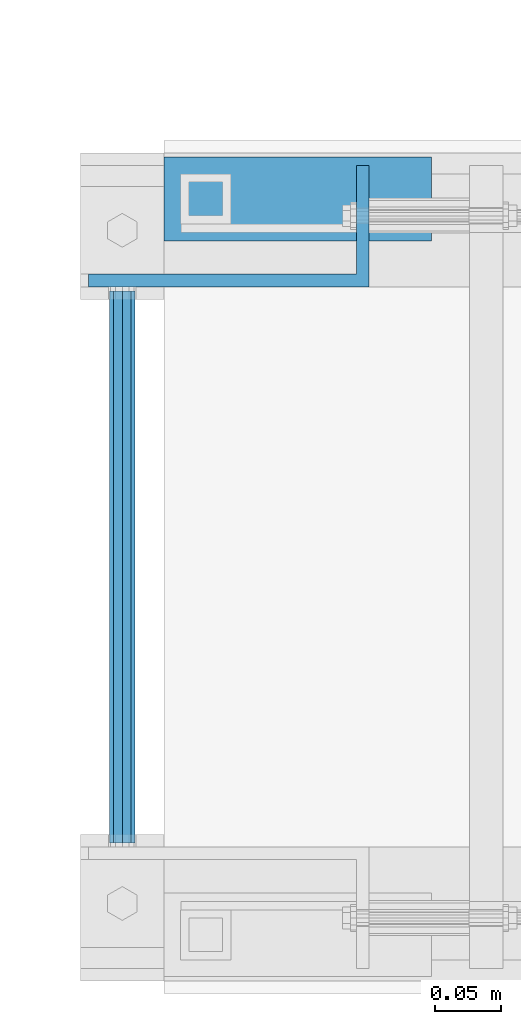
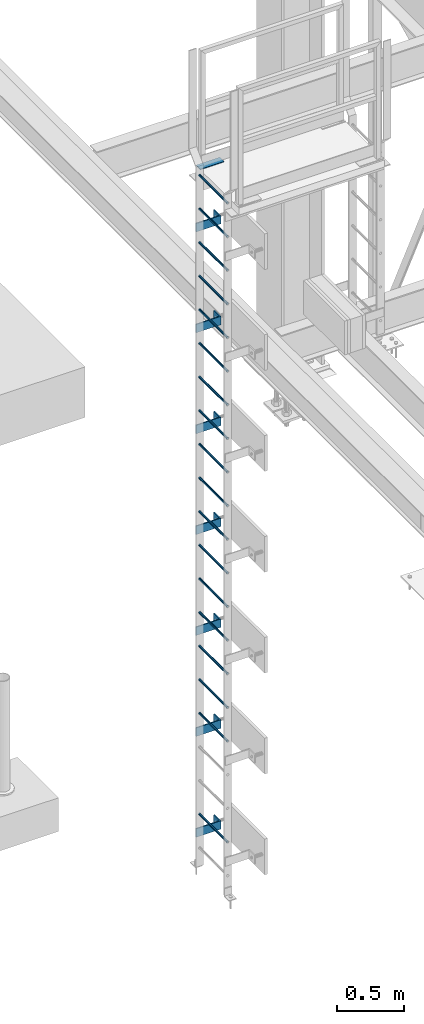
# One storey, part 2015 of 3843: 26 beams, 2 elements without a shape of their own.
"""IFC2X3 building model written with IfcOpenShell, lengths in millimetres."""

from ifc_helpers import new_model, si_unit, frame, origin_with_axes, place, context, subcontext, project, spatial, faceted_brep, material, type_object, element, aggregate, save


model = new_model("IFC2X3")

# Units and contexts
model_context = context("Model", 3, precision=1e-05, world=origin_with_axes())
body_context = subcontext(model_context, "Body", "Model", "MODEL_VIEW")
ifc_project = project(units=[si_unit("LENGTHUNIT", "METRE", prefix="MILLI"), si_unit("AREAUNIT", "SQUARE_METRE"), si_unit("VOLUMEUNIT", "CUBIC_METRE"), si_unit("MASSUNIT", "GRAM", prefix="KILO"), si_unit("TIMEUNIT", "SECOND"), si_unit("PLANEANGLEUNIT", "RADIAN"), si_unit("SOLIDANGLEUNIT", "STERADIAN"), si_unit("THERMODYNAMICTEMPERATUREUNIT", "DEGREE_CELSIUS"), si_unit("LUMINOUSINTENSITYUNIT", "LUMEN")], contexts=[model_context])

# Site, building, storey
site_placement = place(None, origin_with_axes())
site = spatial("IfcSite", under=ifc_project, at=site_placement, CompositionType="ELEMENT")
building_placement = place(site_placement, origin_with_axes())
building = spatial("IfcBuilding", under=site, at=building_placement, Name="Undefined", CompositionType="ELEMENT")
storey_placement = place(building_placement, origin_with_axes())
storey = spatial("IfcBuildingStorey", under=building, at=storey_placement, Name="Undefined", CompositionType="ELEMENT", Elevation=0.0)

# Assembly, beams
assembly_1_placement = place(storey_placement, origin_with_axes())
assembly_1 = element("IfcElementAssembly", 1, at=assembly_1_placement, inside=storey, Name="LADDER", AssemblyPlace="NOTDEFINED", PredefinedType="RIGID_FRAME")
ifc_material_1 = material(Name="STEEL/A36")
beam_type_1 = type_object("IfcBeamType", PredefinedType="NOTDEFINED")
beam_1_placement = place(assembly_1_placement, frame((32400.1940668828, 28017.7875000009, 36281.9334228516), z_axis=(0.0, 0.0, 1.0), x_axis=(1.0, 0.0, 0.0)))
beam_1 = element("IfcBeam", 2, at=beam_1_placement, type_object=beam_type_1, material=ifc_material_1, Name="BENT_PLATE", context=body_context, shape_type="Brep", body=[
    faceted_brep([(0.0, -4.76250000000073, -38.0999999999985), (0.0, -4.76250000000073, 38.0999999999985), (0.0, 4.76250000000073, 38.0999999999985), (0.0, 4.76250000000073, -38.0999999999985), (203.398438000007, 4.762500000008, 38.0999999999985), (203.398438000007, 4.762500000008, -38.0999999999985), (212.923438000009, -4.76249999999345, -38.0999999999985), (212.923438000009, -4.76249999999345, 38.0999999999985), (203.398438000007, 87.312499999498, 38.0999999999985), (203.398438000007, 87.312499999498, -38.0999999999985), (212.923438000009, 87.312499999498, 38.0999999999985), (212.923438000009, 87.312499999498, -38.0999999999985)], [[[0, 1, 2, 3]], [[3, 2, 4, 5]], [[1, 0, 6, 7]], [[5, 4, 8, 9]], [[4, 2, 1, 7, 10, 8]], [[7, 6, 11, 10]], [[6, 0, 3, 5, 9, 11]], [[10, 11, 9, 8]]]),
])
beam_2_placement = place(assembly_1_placement, frame((32400.1940668828, 28017.7875000009, 35367.5334228516), z_axis=(0.0, 0.0, 1.0), x_axis=(1.0, 0.0, 0.0)))
beam_2 = element("IfcBeam", 3, at=beam_2_placement, type_object=beam_type_1, material=ifc_material_1, Name="BENT_PLATE", context=body_context, shape_type="Brep", body=[
    faceted_brep([(0.0, -4.76250000000073, -38.0999999999985), (0.0, -4.76250000000073, 38.0999999999985), (0.0, 4.76250000000073, 38.0999999999985), (0.0, 4.76250000000073, -38.0999999999985), (203.398438000007, 4.762500000008, 38.0999999999985), (203.398438000007, 4.762500000008, -38.0999999999985), (212.923438000009, -4.76249999999345, -38.0999999999985), (212.923438000009, -4.76249999999345, 38.0999999999985), (203.398438000007, 87.312499999498, 38.0999999999985), (203.398438000007, 87.312499999498, -38.0999999999985), (212.923438000009, 87.312499999498, 38.0999999999985), (212.923438000009, 87.312499999498, -38.0999999999985)], [[[0, 1, 2, 3]], [[3, 2, 4, 5]], [[1, 0, 6, 7]], [[5, 4, 8, 9]], [[4, 2, 1, 7, 10, 8]], [[7, 6, 11, 10]], [[6, 0, 3, 5, 9, 11]], [[10, 11, 9, 8]]]),
])
beam_3_placement = place(assembly_1_placement, frame((32400.1940668828, 28017.7875000009, 34453.1334228516), z_axis=(0.0, 0.0, 1.0), x_axis=(1.0, 0.0, 0.0)))
beam_3 = element("IfcBeam", 4, at=beam_3_placement, type_object=beam_type_1, material=ifc_material_1, Name="BENT_PLATE", context=body_context, shape_type="Brep", body=[
    faceted_brep([(0.0, -4.76250000000073, -38.0999999999985), (0.0, -4.76250000000073, 38.0999999999985), (0.0, 4.76250000000073, 38.0999999999985), (0.0, 4.76250000000073, -38.0999999999985), (203.398438000007, 4.762500000008, 38.0999999999985), (203.398438000007, 4.762500000008, -38.0999999999985), (212.923438000009, -4.76249999999345, -38.0999999999985), (212.923438000009, -4.76249999999345, 38.0999999999985), (203.398438000007, 87.312499999498, 38.0999999999985), (203.398438000007, 87.312499999498, -38.0999999999985), (212.923438000009, 87.312499999498, 38.0999999999985), (212.923438000009, 87.312499999498, -38.0999999999985)], [[[0, 1, 2, 3]], [[3, 2, 4, 5]], [[1, 0, 6, 7]], [[5, 4, 8, 9]], [[4, 2, 1, 7, 10, 8]], [[7, 6, 11, 10]], [[6, 0, 3, 5, 9, 11]], [[10, 11, 9, 8]]]),
])
beam_4_placement = place(assembly_1_placement, frame((32400.1940668828, 28017.7875000009, 33538.7334228516), z_axis=(0.0, 0.0, 1.0), x_axis=(1.0, 0.0, 0.0)))
beam_4 = element("IfcBeam", 5, at=beam_4_placement, type_object=beam_type_1, material=ifc_material_1, Name="BENT_PLATE", context=body_context, shape_type="Brep", body=[
    faceted_brep([(0.0, -4.76250000000073, -38.0999999999985), (0.0, -4.76250000000073, 38.0999999999985), (0.0, 4.76250000000073, 38.0999999999985), (0.0, 4.76250000000073, -38.0999999999985), (203.398438000007, 4.762500000008, 38.0999999999985), (203.398438000007, 4.762500000008, -38.0999999999985), (212.923438000009, -4.76249999999345, -38.0999999999985), (212.923438000009, -4.76249999999345, 38.0999999999985), (203.398438000007, 87.312499999498, 38.0999999999985), (203.398438000007, 87.312499999498, -38.0999999999985), (212.923438000009, 87.312499999498, 38.0999999999985), (212.923438000009, 87.312499999498, -38.0999999999985)], [[[0, 1, 2, 3]], [[3, 2, 4, 5]], [[1, 0, 6, 7]], [[5, 4, 8, 9]], [[4, 2, 1, 7, 10, 8]], [[7, 6, 11, 10]], [[6, 0, 3, 5, 9, 11]], [[10, 11, 9, 8]]]),
])
beam_5_placement = place(assembly_1_placement, frame((32400.1940668828, 28017.7875000009, 32624.3334228516), z_axis=(0.0, 0.0, 1.0), x_axis=(1.0, 0.0, 0.0)))
beam_5 = element("IfcBeam", 6, at=beam_5_placement, type_object=beam_type_1, material=ifc_material_1, Name="BENT_PLATE", context=body_context, shape_type="Brep", body=[
    faceted_brep([(0.0, -4.76250000000073, -38.0999999999985), (0.0, -4.76250000000073, 38.0999999999985), (0.0, 4.76250000000073, 38.0999999999985), (0.0, 4.76250000000073, -38.0999999999985), (203.398438000007, 4.762500000008, 38.0999999999985), (203.398438000007, 4.762500000008, -38.0999999999985), (212.923438000009, -4.76249999999345, -38.0999999999985), (212.923438000009, -4.76249999999345, 38.0999999999985), (203.398438000007, 87.312499999498, 38.0999999999985), (203.398438000007, 87.312499999498, -38.0999999999985), (212.923438000009, 87.312499999498, 38.0999999999985), (212.923438000009, 87.312499999498, -38.0999999999985)], [[[0, 1, 2, 3]], [[3, 2, 4, 5]], [[1, 0, 6, 7]], [[5, 4, 8, 9]], [[4, 2, 1, 7, 10, 8]], [[7, 6, 11, 10]], [[6, 0, 3, 5, 9, 11]], [[10, 11, 9, 8]]]),
])
beam_6_placement = place(assembly_1_placement, frame((32400.1940668828, 28017.7875000009, 31709.9334228516), z_axis=(0.0, 0.0, 1.0), x_axis=(1.0, 0.0, 0.0)))
beam_6 = element("IfcBeam", 7, at=beam_6_placement, type_object=beam_type_1, material=ifc_material_1, Name="BENT_PLATE", context=body_context, shape_type="Brep", body=[
    faceted_brep([(0.0, -4.76250000000073, -38.0999999999985), (0.0, -4.76250000000073, 38.0999999999985), (0.0, 4.76250000000073, 38.0999999999985), (0.0, 4.76250000000073, -38.0999999999985), (203.398438000007, 4.762500000008, 38.0999999999985), (203.398438000007, 4.762500000008, -38.0999999999985), (212.923438000009, -4.76249999999345, -38.0999999999985), (212.923438000009, -4.76249999999345, 38.0999999999985), (203.398438000007, 87.312499999498, 38.0999999999985), (203.398438000007, 87.312499999498, -38.0999999999985), (212.923438000009, 87.312499999498, 38.0999999999985), (212.923438000009, 87.312499999498, -38.0999999999985)], [[[0, 1, 2, 3]], [[3, 2, 4, 5]], [[1, 0, 6, 7]], [[5, 4, 8, 9]], [[4, 2, 1, 7, 10, 8]], [[7, 6, 11, 10]], [[6, 0, 3, 5, 9, 11]], [[10, 11, 9, 8]]]),
])
beam_7_placement = place(assembly_1_placement, frame((32400.1940668828, 28017.7875000009, 30795.5334228516), z_axis=(0.0, 0.0, 1.0), x_axis=(1.0, 0.0, 0.0)))
beam_7 = element("IfcBeam", 8, at=beam_7_placement, type_object=beam_type_1, material=ifc_material_1, Name="BENT_PLATE", context=body_context, shape_type="Brep", body=[
    faceted_brep([(0.0, -4.76250000000073, -38.0999999999985), (0.0, -4.76250000000073, 38.0999999999985), (0.0, 4.76250000000073, 38.0999999999985), (0.0, 4.76250000000073, -38.0999999999985), (203.398438000007, 4.762500000008, 38.0999999999985), (203.398438000007, 4.762500000008, -38.0999999999985), (212.923438000009, -4.76249999999345, -38.0999999999985), (212.923438000009, -4.76249999999345, 38.0999999999985), (203.398438000007, 87.312499999498, 38.0999999999985), (203.398438000007, 87.312499999498, -38.0999999999985), (212.923438000009, 87.312499999498, 38.0999999999985), (212.923438000009, 87.312499999498, -38.0999999999985)], [[[0, 1, 2, 3]], [[3, 2, 4, 5]], [[1, 0, 6, 7]], [[5, 4, 8, 9]], [[4, 2, 1, 7, 10, 8]], [[7, 6, 11, 10]], [[6, 0, 3, 5, 9, 11]], [[10, 11, 9, 8]]]),
])
ifc_material_2 = material(Name="STEEL/A572-50")
beam_type_2 = type_object("IfcBeamType", PredefinedType="NOTDEFINED")
beam_8_placement = place(assembly_1_placement, frame((32425.7733459473, 28009.8499999999, 31878.7155151367), z_axis=(1.0, 0.0, 0.0), x_axis=(0.0, -1.0, 0.0)))
beam_8 = element("IfcBeam", 9, at=beam_8_placement, type_object=beam_type_2, material=ifc_material_2, Name="RUNG", context=body_context, shape_type="Brep", body=[
    faceted_brep([(0.0, -9.52500000000146, 0.0), (0.0, -6.73519209080405, -6.73519209079677), (419.100000000006, -6.73519209080405, -6.73519209079677), (419.100000000006, -9.52500000000146, 0.0), (2.95075507493764e-12, 2.91322521661641e-12, -9.52499961853027), (419.100000000006, 0.0, -9.52499999999418), (0.0, 6.73519209080405, -6.73519209079677), (419.100000000006, 6.73519209080405, -6.73519209079677), (0.0, 9.52500000000146, 0.0), (419.100000000006, 9.52500000000146, 0.0), (0.0, 6.73519209080405, 6.73519209079677), (419.100000000006, 6.73519209080405, 6.73519209079677), (-9.87109982941227e-13, 2.91322521661641e-12, 9.52499961853027), (419.100000000006, 0.0, 9.52499999999418), (0.0, -6.73519209080405, 6.73519209079677), (419.100000000006, -6.73519209080405, 6.73519209079677)], [[[0, 1, 2, 3]], [[1, 4, 5, 2]], [[4, 6, 7, 5]], [[6, 8, 9, 7]], [[8, 10, 11, 9]], [[10, 12, 13, 11]], [[12, 14, 15, 13]], [[14, 0, 3, 15]], [[5, 7, 9, 11, 13, 15, 3, 2]], [[14, 12, 10, 8, 6, 4, 1, 0]]]),
])
beam_9_placement = place(assembly_1_placement, frame((32425.7733459473, 28009.8499999999, 32183.5155151367), z_axis=(1.0, 0.0, 0.0), x_axis=(0.0, -1.0, 0.0)))
beam_9 = element("IfcBeam", 10, at=beam_9_placement, type_object=beam_type_2, material=ifc_material_2, Name="RUNG", context=body_context, shape_type="Brep", body=[
    faceted_brep([(0.0, -9.52500000000146, 0.0), (0.0, -6.73519209080405, -6.73519209079677), (419.100000000006, -6.73519209080405, -6.73519209079677), (419.100000000006, -9.52500000000146, 0.0), (2.95075507493764e-12, 2.91322521661641e-12, -9.52499961853027), (419.100000000006, 0.0, -9.52499999999418), (0.0, 6.73519209080405, -6.73519209079677), (419.100000000006, 6.73519209080405, -6.73519209079677), (0.0, 9.52500000000146, 0.0), (419.100000000006, 9.52500000000146, 0.0), (0.0, 6.73519209080405, 6.73519209079677), (419.100000000006, 6.73519209080405, 6.73519209079677), (-9.87109982941227e-13, 2.91322521661641e-12, 9.52499961853027), (419.100000000006, 0.0, 9.52499999999418), (0.0, -6.73519209080405, 6.73519209079677), (419.100000000006, -6.73519209080405, 6.73519209079677)], [[[0, 1, 2, 3]], [[1, 4, 5, 2]], [[4, 6, 7, 5]], [[6, 8, 9, 7]], [[8, 10, 11, 9]], [[10, 12, 13, 11]], [[12, 14, 15, 13]], [[14, 0, 3, 15]], [[5, 7, 9, 11, 13, 15, 3, 2]], [[14, 12, 10, 8, 6, 4, 1, 0]]]),
])
beam_10_placement = place(assembly_1_placement, frame((32425.7733459473, 28009.8499999999, 32488.3155151367), z_axis=(1.0, 0.0, 0.0), x_axis=(0.0, -1.0, 0.0)))
beam_10 = element("IfcBeam", 11, at=beam_10_placement, type_object=beam_type_2, material=ifc_material_2, Name="RUNG", context=body_context, shape_type="Brep", body=[
    faceted_brep([(0.0, -9.52500000000146, 0.0), (0.0, -6.73519209080405, -6.73519209079677), (419.100000000006, -6.73519209080405, -6.73519209079677), (419.100000000006, -9.52500000000146, 0.0), (2.95075507493764e-12, 2.91322521661641e-12, -9.52499961853027), (419.100000000006, 0.0, -9.52499999999418), (0.0, 6.73519209080405, -6.73519209079677), (419.100000000006, 6.73519209080405, -6.73519209079677), (0.0, 9.52500000000146, 0.0), (419.100000000006, 9.52500000000146, 0.0), (0.0, 6.73519209080405, 6.73519209079677), (419.100000000006, 6.73519209080405, 6.73519209079677), (-9.87109982941227e-13, 2.91322521661641e-12, 9.52499961853027), (419.100000000006, 0.0, 9.52499999999418), (0.0, -6.73519209080405, 6.73519209079677), (419.100000000006, -6.73519209080405, 6.73519209079677)], [[[0, 1, 2, 3]], [[1, 4, 5, 2]], [[4, 6, 7, 5]], [[6, 8, 9, 7]], [[8, 10, 11, 9]], [[10, 12, 13, 11]], [[12, 14, 15, 13]], [[14, 0, 3, 15]], [[5, 7, 9, 11, 13, 15, 3, 2]], [[14, 12, 10, 8, 6, 4, 1, 0]]]),
])
beam_11_placement = place(assembly_1_placement, frame((32425.7733459473, 28009.8499999999, 34621.9155151367), z_axis=(1.0, 0.0, 0.0), x_axis=(0.0, -1.0, 0.0)))
beam_11 = element("IfcBeam", 12, at=beam_11_placement, type_object=beam_type_2, material=ifc_material_2, Name="RUNG", context=body_context, shape_type="Brep", body=[
    faceted_brep([(0.0, -9.52500000000146, 0.0), (0.0, -6.73519209080405, -6.73519209079677), (419.100000000006, -6.73519209080405, -6.73519209079677), (419.100000000006, -9.52500000000146, 0.0), (2.95075507493764e-12, 2.91322521661641e-12, -9.52499961853027), (419.100000000006, 0.0, -9.52499999999418), (0.0, 6.73519209080405, -6.73519209079677), (419.100000000006, 6.73519209080405, -6.73519209079677), (0.0, 9.52500000000146, 0.0), (419.100000000006, 9.52500000000146, 0.0), (0.0, 6.73519209080405, 6.73519209079677), (419.100000000006, 6.73519209080405, 6.73519209079677), (-9.87109982941227e-13, 2.91322521661641e-12, 9.52499961853027), (419.100000000006, 0.0, 9.52499999999418), (0.0, -6.73519209080405, 6.73519209079677), (419.100000000006, -6.73519209080405, 6.73519209079677)], [[[0, 1, 2, 3]], [[1, 4, 5, 2]], [[4, 6, 7, 5]], [[6, 8, 9, 7]], [[8, 10, 11, 9]], [[10, 12, 13, 11]], [[12, 14, 15, 13]], [[14, 0, 3, 15]], [[5, 7, 9, 11, 13, 15, 3, 2]], [[14, 12, 10, 8, 6, 4, 1, 0]]]),
])
beam_12_placement = place(assembly_1_placement, frame((32425.7733459473, 28009.8499999999, 32793.1155151367), z_axis=(1.0, 0.0, 0.0), x_axis=(0.0, -1.0, 0.0)))
beam_12 = element("IfcBeam", 13, at=beam_12_placement, type_object=beam_type_2, material=ifc_material_2, Name="RUNG", context=body_context, shape_type="Brep", body=[
    faceted_brep([(0.0, -9.52500000000146, 0.0), (0.0, -6.73519209080405, -6.73519209079677), (419.100000000006, -6.73519209080405, -6.73519209079677), (419.100000000006, -9.52500000000146, 0.0), (2.95075507493764e-12, 2.91322521661641e-12, -9.52499961853027), (419.100000000006, 0.0, -9.52499999999418), (0.0, 6.73519209080405, -6.73519209079677), (419.100000000006, 6.73519209080405, -6.73519209079677), (0.0, 9.52500000000146, 0.0), (419.100000000006, 9.52500000000146, 0.0), (0.0, 6.73519209080405, 6.73519209079677), (419.100000000006, 6.73519209080405, 6.73519209079677), (-9.87109982941227e-13, 2.91322521661641e-12, 9.52499961853027), (419.100000000006, 0.0, 9.52499999999418), (0.0, -6.73519209080405, 6.73519209079677), (419.100000000006, -6.73519209080405, 6.73519209079677)], [[[0, 1, 2, 3]], [[1, 4, 5, 2]], [[4, 6, 7, 5]], [[6, 8, 9, 7]], [[8, 10, 11, 9]], [[10, 12, 13, 11]], [[12, 14, 15, 13]], [[14, 0, 3, 15]], [[5, 7, 9, 11, 13, 15, 3, 2]], [[14, 12, 10, 8, 6, 4, 1, 0]]]),
])
beam_13_placement = place(assembly_1_placement, frame((32425.7733459473, 28009.8499999999, 33097.9155151367), z_axis=(1.0, 0.0, 0.0), x_axis=(0.0, -1.0, 0.0)))
beam_13 = element("IfcBeam", 14, at=beam_13_placement, type_object=beam_type_2, material=ifc_material_2, Name="RUNG", context=body_context, shape_type="Brep", body=[
    faceted_brep([(0.0, -9.52500000000146, 0.0), (0.0, -6.73519209080405, -6.73519209079677), (419.100000000006, -6.73519209080405, -6.73519209079677), (419.100000000006, -9.52500000000146, 0.0), (2.95075507493764e-12, 2.91322521661641e-12, -9.52499961853027), (419.100000000006, 0.0, -9.52499999999418), (0.0, 6.73519209080405, -6.73519209079677), (419.100000000006, 6.73519209080405, -6.73519209079677), (0.0, 9.52500000000146, 0.0), (419.100000000006, 9.52500000000146, 0.0), (0.0, 6.73519209080405, 6.73519209079677), (419.100000000006, 6.73519209080405, 6.73519209079677), (-9.87109982941227e-13, 2.91322521661641e-12, 9.52499961853027), (419.100000000006, 0.0, 9.52499999999418), (0.0, -6.73519209080405, 6.73519209079677), (419.100000000006, -6.73519209080405, 6.73519209079677)], [[[0, 1, 2, 3]], [[1, 4, 5, 2]], [[4, 6, 7, 5]], [[6, 8, 9, 7]], [[8, 10, 11, 9]], [[10, 12, 13, 11]], [[12, 14, 15, 13]], [[14, 0, 3, 15]], [[5, 7, 9, 11, 13, 15, 3, 2]], [[14, 12, 10, 8, 6, 4, 1, 0]]]),
])
beam_14_placement = place(assembly_1_placement, frame((32425.7733459473, 28009.8499999999, 33402.7155151367), z_axis=(1.0, 0.0, 0.0), x_axis=(0.0, -1.0, 0.0)))
beam_14 = element("IfcBeam", 15, at=beam_14_placement, type_object=beam_type_2, material=ifc_material_2, Name="RUNG", context=body_context, shape_type="Brep", body=[
    faceted_brep([(0.0, -9.52500000000146, 0.0), (0.0, -6.73519209080405, -6.73519209079677), (419.100000000006, -6.73519209080405, -6.73519209079677), (419.100000000006, -9.52500000000146, 0.0), (2.95075507493764e-12, 2.91322521661641e-12, -9.52499961853027), (419.100000000006, 0.0, -9.52499999999418), (0.0, 6.73519209080405, -6.73519209079677), (419.100000000006, 6.73519209080405, -6.73519209079677), (0.0, 9.52500000000146, 0.0), (419.100000000006, 9.52500000000146, 0.0), (0.0, 6.73519209080405, 6.73519209079677), (419.100000000006, 6.73519209080405, 6.73519209079677), (-9.87109982941227e-13, 2.91322521661641e-12, 9.52499961853027), (419.100000000006, 0.0, 9.52499999999418), (0.0, -6.73519209080405, 6.73519209079677), (419.100000000006, -6.73519209080405, 6.73519209079677)], [[[0, 1, 2, 3]], [[1, 4, 5, 2]], [[4, 6, 7, 5]], [[6, 8, 9, 7]], [[8, 10, 11, 9]], [[10, 12, 13, 11]], [[12, 14, 15, 13]], [[14, 0, 3, 15]], [[5, 7, 9, 11, 13, 15, 3, 2]], [[14, 12, 10, 8, 6, 4, 1, 0]]]),
])
beam_15_placement = place(assembly_1_placement, frame((32425.7733459473, 28009.8499999999, 33707.5155151367), z_axis=(1.0, 0.0, 0.0), x_axis=(0.0, -1.0, 0.0)))
beam_15 = element("IfcBeam", 16, at=beam_15_placement, type_object=beam_type_2, material=ifc_material_2, Name="RUNG", context=body_context, shape_type="Brep", body=[
    faceted_brep([(0.0, -9.52500000000146, 0.0), (0.0, -6.73519209080405, -6.73519209079677), (419.100000000006, -6.73519209080405, -6.73519209079677), (419.100000000006, -9.52500000000146, 0.0), (2.95075507493764e-12, 2.91322521661641e-12, -9.52499961853027), (419.100000000006, 0.0, -9.52499999999418), (0.0, 6.73519209080405, -6.73519209079677), (419.100000000006, 6.73519209080405, -6.73519209079677), (0.0, 9.52500000000146, 0.0), (419.100000000006, 9.52500000000146, 0.0), (0.0, 6.73519209080405, 6.73519209079677), (419.100000000006, 6.73519209080405, 6.73519209079677), (-9.87109982941227e-13, 2.91322521661641e-12, 9.52499961853027), (419.100000000006, 0.0, 9.52499999999418), (0.0, -6.73519209080405, 6.73519209079677), (419.100000000006, -6.73519209080405, 6.73519209079677)], [[[0, 1, 2, 3]], [[1, 4, 5, 2]], [[4, 6, 7, 5]], [[6, 8, 9, 7]], [[8, 10, 11, 9]], [[10, 12, 13, 11]], [[12, 14, 15, 13]], [[14, 0, 3, 15]], [[5, 7, 9, 11, 13, 15, 3, 2]], [[14, 12, 10, 8, 6, 4, 1, 0]]]),
])
beam_16_placement = place(assembly_1_placement, frame((32425.7733459473, 28009.8499999999, 34012.3155151367), z_axis=(1.0, 0.0, 0.0), x_axis=(0.0, -1.0, 0.0)))
beam_16 = element("IfcBeam", 17, at=beam_16_placement, type_object=beam_type_2, material=ifc_material_2, Name="RUNG", context=body_context, shape_type="Brep", body=[
    faceted_brep([(0.0, -9.52500000000146, 0.0), (0.0, -6.73519209080405, -6.73519209079677), (419.100000000006, -6.73519209080405, -6.73519209079677), (419.100000000006, -9.52500000000146, 0.0), (2.95075507493764e-12, 2.91322521661641e-12, -9.52499961853027), (419.100000000006, 0.0, -9.52499999999418), (0.0, 6.73519209080405, -6.73519209079677), (419.100000000006, 6.73519209080405, -6.73519209079677), (0.0, 9.52500000000146, 0.0), (419.100000000006, 9.52500000000146, 0.0), (0.0, 6.73519209080405, 6.73519209079677), (419.100000000006, 6.73519209080405, 6.73519209079677), (-9.87109982941227e-13, 2.91322521661641e-12, 9.52499961853027), (419.100000000006, 0.0, 9.52499999999418), (0.0, -6.73519209080405, 6.73519209079677), (419.100000000006, -6.73519209080405, 6.73519209079677)], [[[0, 1, 2, 3]], [[1, 4, 5, 2]], [[4, 6, 7, 5]], [[6, 8, 9, 7]], [[8, 10, 11, 9]], [[10, 12, 13, 11]], [[12, 14, 15, 13]], [[14, 0, 3, 15]], [[5, 7, 9, 11, 13, 15, 3, 2]], [[14, 12, 10, 8, 6, 4, 1, 0]]]),
])
beam_17_placement = place(assembly_1_placement, frame((32425.7733459473, 28009.8499999999, 34317.1155151367), z_axis=(1.0, 0.0, 0.0), x_axis=(0.0, -1.0, 0.0)))
beam_17 = element("IfcBeam", 18, at=beam_17_placement, type_object=beam_type_2, material=ifc_material_2, Name="RUNG", context=body_context, shape_type="Brep", body=[
    faceted_brep([(0.0, -9.52500000000146, 0.0), (0.0, -6.73519209080405, -6.73519209079677), (419.100000000006, -6.73519209080405, -6.73519209079677), (419.100000000006, -9.52500000000146, 0.0), (2.95075507493764e-12, 2.91322521661641e-12, -9.52499961853027), (419.100000000006, 0.0, -9.52499999999418), (0.0, 6.73519209080405, -6.73519209079677), (419.100000000006, 6.73519209080405, -6.73519209079677), (0.0, 9.52500000000146, 0.0), (419.100000000006, 9.52500000000146, 0.0), (0.0, 6.73519209080405, 6.73519209079677), (419.100000000006, 6.73519209080405, 6.73519209079677), (-9.87109982941227e-13, 2.91322521661641e-12, 9.52499961853027), (419.100000000006, 0.0, 9.52499999999418), (0.0, -6.73519209080405, 6.73519209079677), (419.100000000006, -6.73519209080405, 6.73519209079677)], [[[0, 1, 2, 3]], [[1, 4, 5, 2]], [[4, 6, 7, 5]], [[6, 8, 9, 7]], [[8, 10, 11, 9]], [[10, 12, 13, 11]], [[12, 14, 15, 13]], [[14, 0, 3, 15]], [[5, 7, 9, 11, 13, 15, 3, 2]], [[14, 12, 10, 8, 6, 4, 1, 0]]]),
])
beam_18_placement = place(assembly_1_placement, frame((32425.7733459473, 28009.8499999999, 34926.7155151367), z_axis=(1.0, 0.0, 0.0), x_axis=(0.0, -1.0, 0.0)))
beam_18 = element("IfcBeam", 19, at=beam_18_placement, type_object=beam_type_2, material=ifc_material_2, Name="RUNG", context=body_context, shape_type="Brep", body=[
    faceted_brep([(0.0, -9.52500000000146, 0.0), (0.0, -6.73519209080405, -6.73519209079677), (419.100000000006, -6.73519209080405, -6.73519209079677), (419.100000000006, -9.52500000000146, 0.0), (2.95075507493764e-12, 2.91322521661641e-12, -9.52499961853027), (419.100000000006, 0.0, -9.52499999999418), (0.0, 6.73519209080405, -6.73519209079677), (419.100000000006, 6.73519209080405, -6.73519209079677), (0.0, 9.52500000000146, 0.0), (419.100000000006, 9.52500000000146, 0.0), (0.0, 6.73519209080405, 6.73519209079677), (419.100000000006, 6.73519209080405, 6.73519209079677), (-9.87109982941227e-13, 2.91322521661641e-12, 9.52499961853027), (419.100000000006, 0.0, 9.52499999999418), (0.0, -6.73519209080405, 6.73519209079677), (419.100000000006, -6.73519209080405, 6.73519209079677)], [[[0, 1, 2, 3]], [[1, 4, 5, 2]], [[4, 6, 7, 5]], [[6, 8, 9, 7]], [[8, 10, 11, 9]], [[10, 12, 13, 11]], [[12, 14, 15, 13]], [[14, 0, 3, 15]], [[5, 7, 9, 11, 13, 15, 3, 2]], [[14, 12, 10, 8, 6, 4, 1, 0]]]),
])
beam_19_placement = place(assembly_1_placement, frame((32425.7733459473, 28009.8499999999, 35231.5155151367), z_axis=(1.0, 0.0, 0.0), x_axis=(0.0, -1.0, 0.0)))
beam_19 = element("IfcBeam", 20, at=beam_19_placement, type_object=beam_type_2, material=ifc_material_2, Name="RUNG", context=body_context, shape_type="Brep", body=[
    faceted_brep([(0.0, -9.52500000000146, 0.0), (0.0, -6.73519209080405, -6.73519209079677), (419.100000000006, -6.73519209080405, -6.73519209079677), (419.100000000006, -9.52500000000146, 0.0), (2.95075507493764e-12, 2.91322521661641e-12, -9.52499961853027), (419.100000000006, 0.0, -9.52499999999418), (0.0, 6.73519209080405, -6.73519209079677), (419.100000000006, 6.73519209080405, -6.73519209079677), (0.0, 9.52500000000146, 0.0), (419.100000000006, 9.52500000000146, 0.0), (0.0, 6.73519209080405, 6.73519209079677), (419.100000000006, 6.73519209080405, 6.73519209079677), (-9.87109982941227e-13, 2.91322521661641e-12, 9.52499961853027), (419.100000000006, 0.0, 9.52499999999418), (0.0, -6.73519209080405, 6.73519209079677), (419.100000000006, -6.73519209080405, 6.73519209079677)], [[[0, 1, 2, 3]], [[1, 4, 5, 2]], [[4, 6, 7, 5]], [[6, 8, 9, 7]], [[8, 10, 11, 9]], [[10, 12, 13, 11]], [[12, 14, 15, 13]], [[14, 0, 3, 15]], [[5, 7, 9, 11, 13, 15, 3, 2]], [[14, 12, 10, 8, 6, 4, 1, 0]]]),
])
beam_20_placement = place(assembly_1_placement, frame((32425.7733459473, 28009.8499999999, 35536.3155151367), z_axis=(1.0, 0.0, 0.0), x_axis=(0.0, -1.0, 0.0)))
beam_20 = element("IfcBeam", 21, at=beam_20_placement, type_object=beam_type_2, material=ifc_material_2, Name="RUNG", context=body_context, shape_type="Brep", body=[
    faceted_brep([(0.0, -9.52500000000146, 0.0), (0.0, -6.73519209080405, -6.73519209079677), (419.100000000006, -6.73519209080405, -6.73519209079677), (419.100000000006, -9.52500000000146, 0.0), (2.95075507493764e-12, 2.91322521661641e-12, -9.52499961853027), (419.100000000006, 0.0, -9.52499999999418), (0.0, 6.73519209080405, -6.73519209079677), (419.100000000006, 6.73519209080405, -6.73519209079677), (0.0, 9.52500000000146, 0.0), (419.100000000006, 9.52500000000146, 0.0), (0.0, 6.73519209080405, 6.73519209079677), (419.100000000006, 6.73519209080405, 6.73519209079677), (-9.87109982941227e-13, 2.91322521661641e-12, 9.52499961853027), (419.100000000006, 0.0, 9.52499999999418), (0.0, -6.73519209080405, 6.73519209079677), (419.100000000006, -6.73519209080405, 6.73519209079677)], [[[0, 1, 2, 3]], [[1, 4, 5, 2]], [[4, 6, 7, 5]], [[6, 8, 9, 7]], [[8, 10, 11, 9]], [[10, 12, 13, 11]], [[12, 14, 15, 13]], [[14, 0, 3, 15]], [[5, 7, 9, 11, 13, 15, 3, 2]], [[14, 12, 10, 8, 6, 4, 1, 0]]]),
])
beam_21_placement = place(assembly_1_placement, frame((32425.7733459473, 28009.8499999999, 35841.1155151367), z_axis=(1.0, 0.0, 0.0), x_axis=(0.0, -1.0, 0.0)))
beam_21 = element("IfcBeam", 22, at=beam_21_placement, type_object=beam_type_2, material=ifc_material_2, Name="RUNG", context=body_context, shape_type="Brep", body=[
    faceted_brep([(0.0, -9.52500000000146, 0.0), (0.0, -6.73519209080405, -6.73519209079677), (419.100000000006, -6.73519209080405, -6.73519209079677), (419.100000000006, -9.52500000000146, 0.0), (2.95075507493764e-12, 2.91322521661641e-12, -9.52499961853027), (419.100000000006, 0.0, -9.52499999999418), (0.0, 6.73519209080405, -6.73519209079677), (419.100000000006, 6.73519209080405, -6.73519209079677), (0.0, 9.52500000000146, 0.0), (419.100000000006, 9.52500000000146, 0.0), (0.0, 6.73519209080405, 6.73519209079677), (419.100000000006, 6.73519209080405, 6.73519209079677), (-9.87109982941227e-13, 2.91322521661641e-12, 9.52499961853027), (419.100000000006, 0.0, 9.52499999999418), (0.0, -6.73519209080405, 6.73519209079677), (419.100000000006, -6.73519209080405, 6.73519209079677)], [[[0, 1, 2, 3]], [[1, 4, 5, 2]], [[4, 6, 7, 5]], [[6, 8, 9, 7]], [[8, 10, 11, 9]], [[10, 12, 13, 11]], [[12, 14, 15, 13]], [[14, 0, 3, 15]], [[5, 7, 9, 11, 13, 15, 3, 2]], [[14, 12, 10, 8, 6, 4, 1, 0]]]),
])
beam_22_placement = place(assembly_1_placement, frame((32425.7733459473, 28009.8499999999, 36145.9155151367), z_axis=(1.0, 0.0, 0.0), x_axis=(0.0, -1.0, 0.0)))
beam_22 = element("IfcBeam", 23, at=beam_22_placement, type_object=beam_type_2, material=ifc_material_2, Name="RUNG", context=body_context, shape_type="Brep", body=[
    faceted_brep([(0.0, -9.52500000000146, 0.0), (0.0, -6.73519209080405, -6.73519209079677), (419.100000000006, -6.73519209080405, -6.73519209079677), (419.100000000006, -9.52500000000146, 0.0), (2.95075507493764e-12, 2.91322521661641e-12, -9.52499961853027), (419.100000000006, 0.0, -9.52499999999418), (0.0, 6.73519209080405, -6.73519209079677), (419.100000000006, 6.73519209080405, -6.73519209079677), (0.0, 9.52500000000146, 0.0), (419.100000000006, 9.52500000000146, 0.0), (0.0, 6.73519209080405, 6.73519209079677), (419.100000000006, 6.73519209080405, 6.73519209079677), (-9.87109982941227e-13, 2.91322521661641e-12, 9.52499961853027), (419.100000000006, 0.0, 9.52499999999418), (0.0, -6.73519209080405, 6.73519209079677), (419.100000000006, -6.73519209080405, 6.73519209079677)], [[[0, 1, 2, 3]], [[1, 4, 5, 2]], [[4, 6, 7, 5]], [[6, 8, 9, 7]], [[8, 10, 11, 9]], [[10, 12, 13, 11]], [[12, 14, 15, 13]], [[14, 0, 3, 15]], [[5, 7, 9, 11, 13, 15, 3, 2]], [[14, 12, 10, 8, 6, 4, 1, 0]]]),
])
beam_23_placement = place(assembly_1_placement, frame((32425.7733459473, 28009.8499999999, 36450.7155151367), z_axis=(1.0, 0.0, 0.0), x_axis=(0.0, -1.0, 0.0)))
beam_23 = element("IfcBeam", 24, at=beam_23_placement, type_object=beam_type_2, material=ifc_material_2, Name="RUNG", context=body_context, shape_type="Brep", body=[
    faceted_brep([(0.0, -9.52500000000146, 0.0), (0.0, -6.73519209080405, -6.73519209079677), (419.100000000006, -6.73519209080405, -6.73519209079677), (419.100000000006, -9.52500000000146, 0.0), (2.95075507493764e-12, 2.91322521661641e-12, -9.52499961853027), (419.100000000006, 0.0, -9.52499999999418), (0.0, 6.73519209080405, -6.73519209079677), (419.100000000006, 6.73519209080405, -6.73519209079677), (0.0, 9.52500000000146, 0.0), (419.100000000006, 9.52500000000146, 0.0), (0.0, 6.73519209080405, 6.73519209079677), (419.100000000006, 6.73519209080405, 6.73519209079677), (-9.87109982941227e-13, 2.91322521661641e-12, 9.52499961853027), (419.100000000006, 0.0, 9.52499999999418), (0.0, -6.73519209080405, 6.73519209079677), (419.100000000006, -6.73519209080405, 6.73519209079677)], [[[0, 1, 2, 3]], [[1, 4, 5, 2]], [[4, 6, 7, 5]], [[6, 8, 9, 7]], [[8, 10, 11, 9]], [[10, 12, 13, 11]], [[12, 14, 15, 13]], [[14, 0, 3, 15]], [[5, 7, 9, 11, 13, 15, 3, 2]], [[14, 12, 10, 8, 6, 4, 1, 0]]]),
])
beam_24_placement = place(assembly_1_placement, frame((32425.7733459473, 28009.8499999999, 36755.5155151367), z_axis=(1.0, 0.0, 0.0), x_axis=(0.0, -1.0, 0.0)))
beam_24 = element("IfcBeam", 25, at=beam_24_placement, type_object=beam_type_2, material=ifc_material_2, Name="RUNG", context=body_context, shape_type="Brep", body=[
    faceted_brep([(0.0, -9.52500000000146, 0.0), (0.0, -6.73519209080405, -6.73519209079677), (419.100000000006, -6.73519209080405, -6.73519209079677), (419.100000000006, -9.52500000000146, 0.0), (2.95075507493764e-12, 2.91322521661641e-12, -9.52499961853027), (419.100000000006, 0.0, -9.52499999999418), (0.0, 6.73519209080405, -6.73519209079677), (419.100000000006, 6.73519209080405, -6.73519209079677), (0.0, 9.52500000000146, 0.0), (419.100000000006, 9.52500000000146, 0.0), (0.0, 6.73519209080405, 6.73519209079677), (419.100000000006, 6.73519209080405, 6.73519209079677), (-9.87109982941227e-13, 2.91322521661641e-12, 9.52499961853027), (419.100000000006, 0.0, 9.52499999999418), (0.0, -6.73519209080405, 6.73519209079677), (419.100000000006, -6.73519209080405, 6.73519209079677)], [[[0, 1, 2, 3]], [[1, 4, 5, 2]], [[4, 6, 7, 5]], [[6, 8, 9, 7]], [[8, 10, 11, 9]], [[10, 12, 13, 11]], [[12, 14, 15, 13]], [[14, 0, 3, 15]], [[5, 7, 9, 11, 13, 15, 3, 2]], [[14, 12, 10, 8, 6, 4, 1, 0]]]),
])
beam_25_placement = place(assembly_1_placement, frame((32425.7733459473, 28009.8499999999, 30964.3155151367), z_axis=(1.0, 0.0, 0.0), x_axis=(0.0, -1.0, 0.0)))
beam_25 = element("IfcBeam", 26, at=beam_25_placement, type_object=beam_type_2, material=ifc_material_2, Name="RUNG", context=body_context, shape_type="Brep", body=[
    faceted_brep([(0.0, -9.52500000000146, 0.0), (0.0, -6.73519209080405, -6.73519209079677), (419.100000000006, -6.73519209080405, -6.73519209079677), (419.100000000006, -9.52500000000146, 0.0), (2.95075507493764e-12, 2.91322521661641e-12, -9.52499961853027), (419.100000000006, 0.0, -9.52499999999418), (0.0, 6.73519209080405, -6.73519209079677), (419.100000000006, 6.73519209080405, -6.73519209079677), (0.0, 9.52500000000146, 0.0), (419.100000000006, 9.52500000000146, 0.0), (0.0, 6.73519209080405, 6.73519209079677), (419.100000000006, 6.73519209080405, 6.73519209079677), (-9.87109982941227e-13, 2.91322521661641e-12, 9.52499961853027), (419.100000000006, 0.0, 9.52499999999418), (0.0, -6.73519209080405, 6.73519209079677), (419.100000000006, -6.73519209080405, 6.73519209079677)], [[[0, 1, 2, 3]], [[1, 4, 5, 2]], [[4, 6, 7, 5]], [[6, 8, 9, 7]], [[8, 10, 11, 9]], [[10, 12, 13, 11]], [[12, 14, 15, 13]], [[14, 0, 3, 15]], [[5, 7, 9, 11, 13, 15, 3, 2]], [[14, 12, 10, 8, 6, 4, 1, 0]]]),
])
aggregate(assembly_1, [beam_1, beam_2, beam_3, beam_4, beam_5, beam_6, beam_7, beam_8, beam_9, beam_10, beam_11, beam_12, beam_13, beam_14, beam_15, beam_16, beam_17, beam_18, beam_19, beam_20, beam_21, beam_22, beam_23, beam_24, beam_25])

# Assembly, beam
assembly_2_placement = place(storey_placement, origin_with_axes())
assembly_2 = element("IfcElementAssembly", 27, at=assembly_2_placement, inside=storey, Name="RAIL", AssemblyPlace="NOTDEFINED", PredefinedType="RIGID_FRAME")
beam_type_3 = type_object("IfcBeamType", PredefinedType="NOTDEFINED")
beam_26_placement = place(assembly_2_placement, frame((32660.6296738373, 28079.6999999999, 36768.7510559082), z_axis=(0.0, -1.0, 0.0), x_axis=(-1.0, 0.0, 0.0)))
beam_26 = element("IfcBeam", 28, at=beam_26_placement, type_object=beam_type_3, material=ifc_material_1, context=body_context, shape_type="Brep", body=[
    faceted_brep([(0.0, 3.17500000000291, -31.75), (0.0, 3.17500000000291, 31.75), (203.199998088516, 3.17500000000291, 31.75), (203.199998088516, 3.17500000000291, -31.75), (0.0, -3.17500000000291, 31.75), (203.199998088516, -3.17500000000291, 31.75), (0.0, -3.17500000000291, -31.75), (203.199998088516, -3.17500000000291, -31.75)], [[[0, 1, 2, 3]], [[1, 4, 5, 2]], [[4, 6, 7, 5]], [[6, 0, 3, 7]], [[5, 7, 3, 2]], [[6, 4, 1, 0]]]),
])
aggregate(assembly_2, [beam_26])

save(model, "model.ifc")
